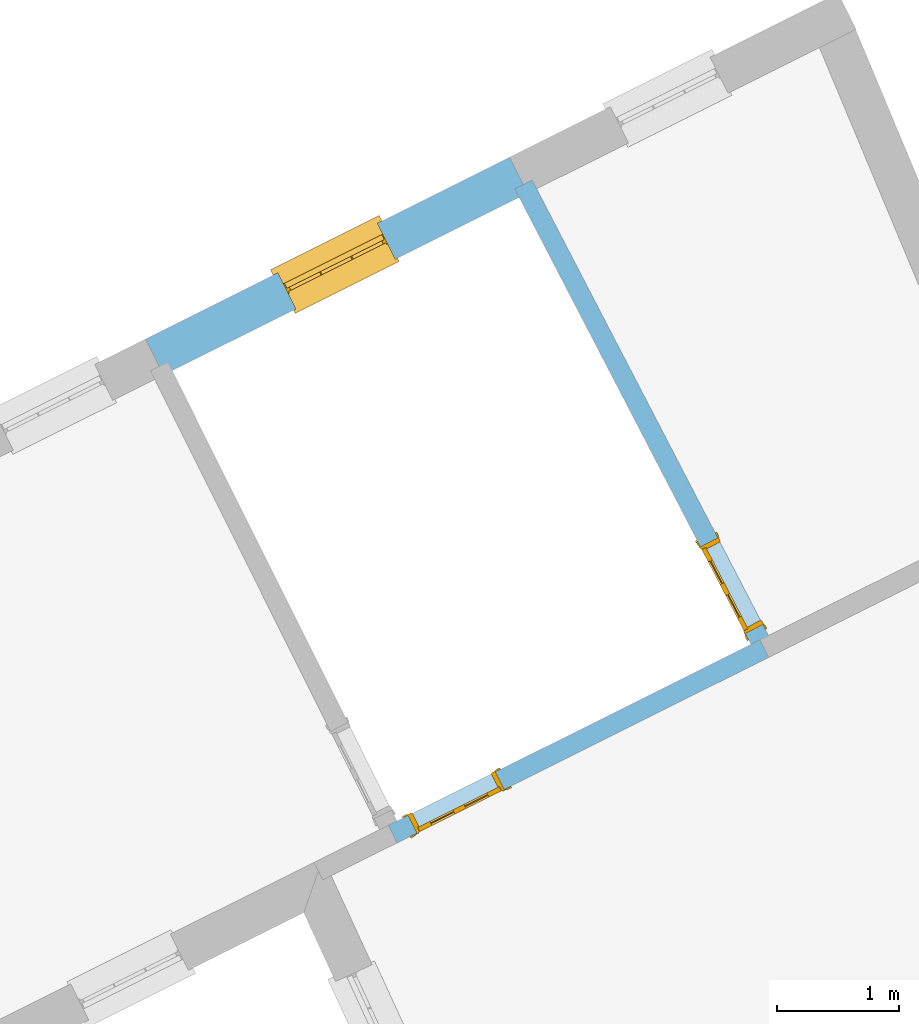
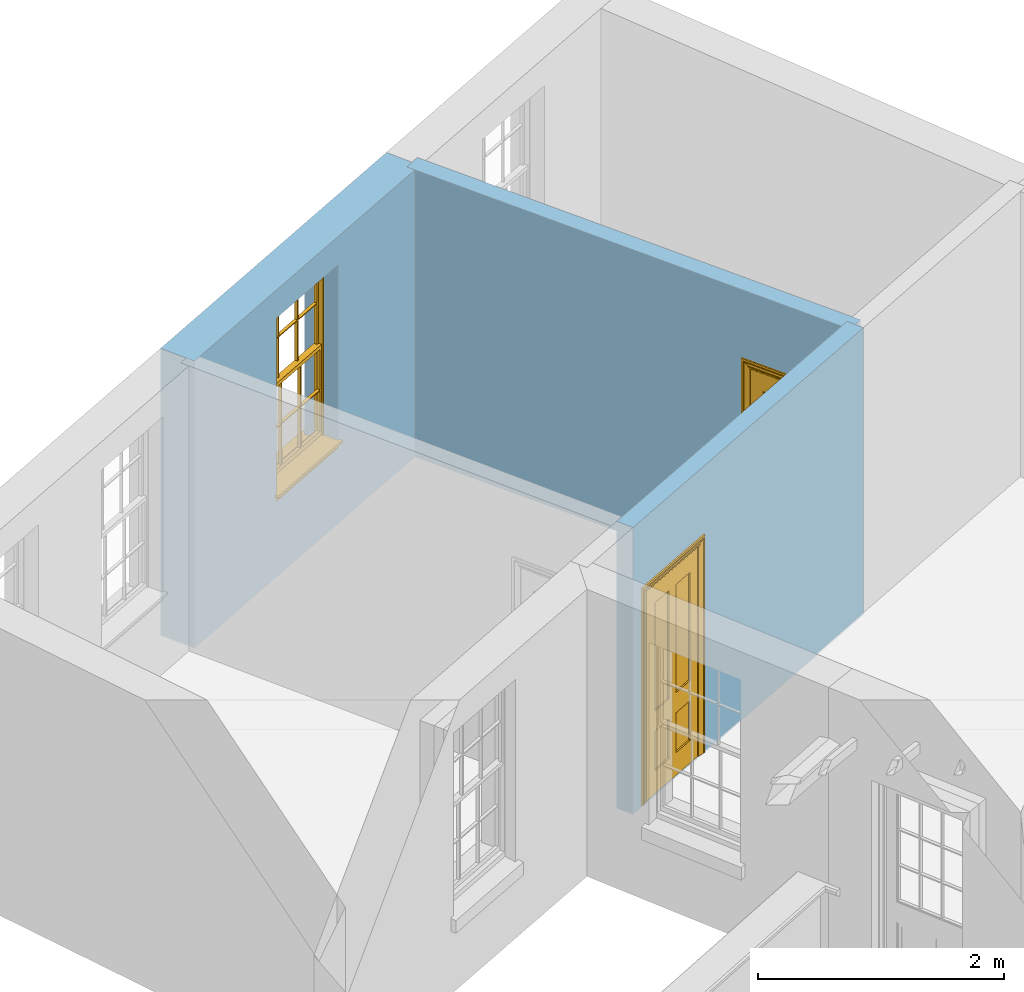
# One storey, part 6 of 9: 2 doors, 1 window, 3 openings, plus 3 elements that do not belong to this part.
"""IFC2X3 building model written with IfcOpenShell, lengths in metres."""

from ifc_helpers import new_model, si_unit, frame, origin, place, context, subcontext, project, spatial, polyline, outline, extrude, faceted_brep, material, layer, layer_set, layer_usage, element, fill, save


model = new_model("IFC2X3")

# Units and contexts
model_context = context("Model", 3, world=origin())
body_context = subcontext(model_context, "Body", "Model", "MODEL_VIEW")
ifc_project = project(units=[si_unit("PLANEANGLEUNIT", "RADIAN"), si_unit("MASSUNIT", "GRAM", prefix="KILO"), si_unit("FORCEUNIT", "NEWTON", prefix="KILO"), si_unit("LENGTHUNIT", "METRE")], contexts=[model_context])

# Site, building, storey
site_placement = place(None, origin())
site = spatial("IfcSite", under=ifc_project, at=site_placement, CompositionType="ELEMENT")
building_placement = place(None, origin())
building = spatial("IfcBuilding", under=site, at=building_placement, Name="Building plot-8", CompositionType="ELEMENT")
storey_placement = place(None, frame((0.0, 0.0, 3.45)))
storey = spatial("IfcBuildingStorey", under=building, at=storey_placement, Name="Floor 1", CompositionType="ELEMENT", Elevation=3.45)

# Wall, opening, window
ifc_material_1 = material(Name="Masonry")
ifc_layer_1 = layer(ifc_material_1, 0.33, ventilated=False)
ifc_layer_set_1 = layer_set([ifc_layer_1], Name="My Wall")
ifc_layer_usage_1 = layer_usage(ifc_layer_set_1, "AXIS2", "NEGATIVE", 0.08)
wall_1_placement = place(storey_placement, origin())
wall_1 = element("IfcWallStandardCase", 1, at=wall_1_placement, inside=storey, material=ifc_layer_usage_1, Name="exterior", context=body_context, shape_type="SweptSolid", body=[
    extrude(outline(polyline([(25.5117707560258, 18.5944455583952), (25.3643689149095, 18.889695786567), (22.3860129541837, 17.4027700868685), (22.5334147953, 17.1075198586967), (25.5117707560258, 18.5944455583952)])), origin(), (0.0, 0.0, 1.0), 2.85),
])
opening_1_placement = place(storey_placement, frame((0.0, 0.0, 0.75)))
opening_1 = element("IfcOpeningElement", 2, at=opening_1_placement, cuts=wall_1, Name="Opening", ObjectType="Opening", context=body_context, shape_type="SweptSolid", body=[
    extrude(outline(polyline([(24.2822783703593, 18.3494688085599), (23.4681034987339, 17.9429970648756), (23.6155053398501, 17.6477468367038), (24.4296802114756, 18.054218580388), (24.2822783703593, 18.3494688085599)])), origin(), (0.0, 0.0, 1.0), 1.82),
])
window_placement = place(storey_placement, frame((24.393946431811, 18.1257943932782, 0.75), z_axis=(0.0, 0.0, 1.0), x_axis=(-0.814174871625433, -0.406471743684246, 0.0)))
window = element("IfcWindow", 3, at=window_placement, inside=storey, Name="circulation outside window", OverallHeight=1.82, OverallWidth=0.91, context=body_context, shape_type="Brep", held_by="IfcProductRepresentation", body=[
    faceted_brep([(0.033125, -0.105, 0.975209), (0.01, -0.105, 0.975209), (0.033125, -0.105, 1.376042), (0.876875, -0.105, 0.975209), (0.876875, -0.105, 1.376042), (0.9, -0.105, 0.975209), (0.876875, -0.105, 1.386042), (0.876875, -0.105, 1.786875), (0.9, -0.105, 1.81), (0.033125, -0.105, 1.786875), (0.033125, -0.105, 1.386042), (0.01, -0.105, 1.81), (0.876875, -0.135, 1.376042), (0.876875, -0.135, 0.975209), (0.9, -0.135, 0.937083), (0.033125, -0.135, 1.786875), (0.01, -0.135, 1.81), (0.033125, -0.135, 1.386042), (0.01, -0.135, 0.937083), (0.033125, -0.135, 0.975209), (0.033125, -0.135, 1.376042), (0.876875, -0.135, 1.786875), (0.876875, -0.135, 1.386042), (0.9, -0.135, 1.81), (0.033125, -0.105, 0.937083), (0.01, -0.105, 0.937083), (0.033125, -0.105, 0.53625), (0.876875, -0.105, 0.937083), (0.876875, -0.105, 0.53625), (0.9, -0.105, 0.937083), (0.876875, -0.105, 0.52625), (0.876875, -0.105, 0.125417), (0.9, -0.105, 0.077167), (0.033125, -0.105, 0.125417), (0.033125, -0.105, 0.52625), (0.01, -0.105, 0.077167), (-0.0425, -0.25, 0.01), (-0.0425, -0.3, 0.001667), (0.0, -0.25, 0.01), (0.9525, -0.25, 0.01), (0.91, -0.25, 0.01), (0.9525, -0.3, 0.001667), (-0.02, 0.08, 0.077167), (0.0, 0.08, 0.077167), (-0.02, 0.11, 0.077167), (0.0, -0.06, 0.077167), (0.01, -0.06, 0.077167), (0.91, -0.06, 0.077167), (0.91, 0.08, 0.077167), (0.9, -0.06, 0.077167), (0.93, 0.08, 0.077167), (0.93, 0.11, 0.077167), (0.01, -0.075, 0.975209), (0.9, -0.075, 0.975209), (0.876875, -0.075, 0.125417), (0.876875, -0.075, 0.52625), (0.9, -0.075, 0.077167), (0.876875, -0.075, 0.53625), (0.876875, -0.075, 0.937083), (0.033125, -0.075, 0.125417), (0.01, -0.075, 0.077167), (0.033125, -0.075, 0.52625), (0.033125, -0.075, 0.937083), (0.033125, -0.075, 0.53625), (-0.02, 0.08, 0.052167), (-0.02, 0.11, 0.052167), (0.93, 0.11, 0.052167), (0.93, 0.08, 0.052167), (0.91, 0.08, 0.052167), (0.0, 0.08, 0.052167), (0.91, -0.15, 0.026667), (0.0, -0.15, 0.026667), (-0.0425, -0.3, -0.123333), (0.9525, -0.3, -0.123333), (-0.0425, -0.25, -0.123333), (0.9525, -0.25, -0.123333), (0.01, -0.06, 1.81), (0.9, -0.06, 1.81), (0.0, -0.06, 1.82), (0.91, -0.06, 1.82), (0.01, -0.15, 0.077167), (0.9, -0.15, 0.077167), (0.592292, -0.105, 0.125417), (0.592292, -0.075, 0.125417), (0.317708, -0.075, 0.125417), (0.317708, -0.105, 0.125417), (0.592292, -0.105, 0.53625), (0.317708, -0.105, 0.53625), (0.317708, -0.105, 0.52625), (0.592292, -0.105, 0.52625), (0.592292, -0.075, 0.53625), (0.317708, -0.075, 0.53625), (0.592292, -0.135, 1.386042), (0.592292, -0.105, 1.386042), (0.317708, -0.105, 1.386042), (0.317708, -0.135, 1.386042), (0.317708, -0.135, 1.376042), (0.592292, -0.135, 1.376042), (0.317708, -0.105, 1.376042), (0.592292, -0.105, 1.376042), (0.602292, -0.135, 1.376042), (0.592292, -0.135, 0.975209), (0.602292, -0.135, 0.975209), (0.602292, -0.105, 0.975209), (0.592292, -0.105, 0.975209), (0.602292, -0.105, 1.376042), (0.602292, -0.075, 0.53625), (0.602292, -0.105, 0.53625), (0.317708, -0.075, 0.52625), (0.307708, -0.075, 0.125417), (0.307708, -0.075, 0.52625), (0.602292, -0.075, 0.52625), (0.602292, -0.075, 0.125417), (0.592292, -0.075, 0.52625), (0.307708, -0.075, 0.53625), (0.317708, -0.075, 0.937083), (0.307708, -0.075, 0.937083), (0.602292, -0.075, 0.937083), (0.592292, -0.075, 0.937083), (0.307708, -0.105, 0.52625), (0.307708, -0.105, 0.125417), (0.307708, -0.105, 0.53625), (0.307708, -0.105, 0.937083), (0.592292, -0.105, 0.937083), (0.317708, -0.105, 0.937083), (0.602292, -0.105, 0.937083), (0.602292, -0.105, 0.52625), (0.602292, -0.105, 0.125417), (0.307708, -0.135, 1.386042), (0.307708, -0.135, 1.376042), (0.307708, -0.135, 0.975209), (0.317708, -0.135, 0.975209), (0.317708, -0.135, 1.786875), (0.307708, -0.135, 1.786875), (0.602292, -0.135, 1.786875), (0.592292, -0.135, 1.786875), (0.602292, -0.135, 1.386042), (0.602292, -0.105, 1.386042), (0.307708, -0.105, 1.386042), (0.307708, -0.105, 1.786875), (0.317708, -0.105, 1.786875), (0.592292, -0.105, 1.786875), (0.602292, -0.105, 1.786875), (0.307708, -0.105, 1.376042), (0.317708, -0.105, 0.975209), (0.307708, -0.105, 0.975209), (0.91, -0.15, 1.82), (0.9, -0.15, 1.81), (0.01, -0.15, 1.81), (0.0, -0.15, 1.82), (0.91, -0.25, 0.0), (0.0, -0.25, 0.0), (0.91, 0.08, 0.0), (0.0, 0.08, 0.0)], [[[0, 1, 2]], [[3, 4, 5]], [[6, 7, 8]], [[9, 10, 11]], [[12, 13, 14]], [[15, 16, 17]], [[18, 19, 20]], [[21, 22, 23]], [[24, 25, 26]], [[27, 28, 29]], [[30, 31, 32]], [[33, 34, 35]], [[14, 27, 29]], [[25, 24, 18]], [[36, 37, 38]], [[39, 40, 41]], [[42, 43, 44]], [[45, 46, 43]], [[47, 48, 49]], [[50, 51, 48]], [[1, 0, 52]], [[5, 53, 3]], [[54, 55, 56]], [[57, 58, 53]], [[59, 60, 61]], [[62, 63, 52]], [[48, 43, 46, 49]], [[51, 44, 43, 48]], [[64, 42, 44, 65]], [[65, 44, 51, 66]], [[66, 51, 50, 67]], [[65, 66, 68, 69]], [[60, 56, 49, 46]], [[70, 71, 38, 40]], [[37, 41, 40, 38]], [[37, 72, 73, 41]], [[74, 75, 73, 72]], [[8, 11, 76, 77]], [[76, 78, 79, 77]], [[32, 35, 80, 81]], [[81, 80, 71, 70]], [[82, 83, 84, 85]], [[86, 87, 88, 89]], [[86, 90, 91, 87]], [[92, 93, 94, 95]], [[92, 95, 96, 97]], [[96, 98, 99, 97]], [[100, 97, 101, 102]], [[103, 104, 99, 105]], [[97, 99, 104, 101]], [[102, 103, 105, 100]], [[28, 57, 106, 107]], [[108, 84, 109, 110]], [[111, 112, 83, 113]], [[114, 110, 61, 63]], [[90, 113, 108, 91]], [[115, 91, 114, 116]], [[117, 106, 90, 118]], [[111, 106, 57, 55]], [[119, 110, 109, 120]], [[34, 61, 110, 119]], [[89, 113, 83, 82]], [[88, 108, 113, 89]], [[85, 84, 108, 88]], [[121, 114, 63, 26]], [[122, 116, 114, 121]], [[123, 118, 90, 86]], [[87, 91, 115, 124]], [[107, 106, 117, 125]], [[126, 111, 55, 30]], [[127, 112, 111, 126]], [[126, 30, 28, 107]], [[88, 119, 120, 85]], [[126, 89, 82, 127]], [[125, 123, 86, 107]], [[121, 26, 34, 119]], [[124, 122, 121, 87]], [[128, 17, 20, 129]], [[96, 129, 130, 131]], [[132, 133, 128, 95]], [[134, 135, 92, 136]], [[100, 12, 22, 136]], [[137, 6, 4, 105]], [[94, 138, 139, 140]], [[137, 93, 141, 142]], [[99, 98, 94, 93]], [[143, 2, 10, 138]], [[144, 145, 143, 98]], [[129, 143, 145, 130]], [[20, 2, 143, 129]], [[131, 144, 98, 96]], [[128, 138, 10, 17]], [[133, 139, 138, 128]], [[135, 141, 93, 92]], [[95, 94, 140, 132]], [[22, 6, 137, 136]], [[136, 137, 142, 134]], [[100, 105, 4, 12]], [[107, 86, 89, 126]], [[106, 111, 113, 90]], [[91, 108, 110, 114]], [[87, 121, 119, 88]], [[97, 100, 136, 92]], [[129, 96, 95, 128]], [[98, 143, 138, 94]], [[105, 99, 93, 137]], [[131, 101, 104, 144]], [[124, 115, 118, 123]], [[132, 140, 141, 135]], [[120, 109, 59, 33]], [[15, 9, 139, 133]], [[134, 142, 7, 21]], [[31, 54, 112, 127]], [[36, 74, 72, 37]], [[39, 41, 73, 75]], [[18, 14, 101, 131]], [[23, 16, 132, 135]], [[83, 56, 60, 84]], [[52, 53, 118, 115]], [[53, 52, 144, 104]], [[11, 8, 141, 140]], [[14, 18, 124, 123]], [[2, 1, 11, 10]], [[8, 5, 4, 6]], [[57, 53, 56, 55]], [[60, 52, 63, 61]], [[26, 25, 35, 34]], [[32, 29, 28, 30]], [[14, 23, 22, 12]], [[18, 20, 17, 16]], [[19, 0, 2, 20]], [[17, 10, 9, 15]], [[12, 4, 3, 13]], [[21, 7, 6, 22]], [[27, 58, 57, 28]], [[30, 55, 54, 31]], [[33, 59, 61, 34]], [[26, 63, 62, 24]], [[5, 8, 77, 53]], [[76, 11, 1, 52]], [[46, 45, 78, 76]], [[49, 77, 79, 47]], [[70, 146, 147, 81]], [[71, 80, 148, 149]], [[19, 130, 145, 0]], [[102, 13, 3, 103]], [[116, 122, 24, 62]], [[29, 32, 81, 14]], [[80, 35, 25, 18]], [[60, 46, 76, 52]], [[77, 49, 56, 53]], [[23, 14, 81, 147]], [[16, 148, 80, 18]], [[35, 85, 120]], [[120, 33, 35]], [[127, 82, 32]], [[32, 31, 127]], [[32, 82, 85, 35]], [[102, 101, 14]], [[14, 13, 102]], [[18, 131, 130]], [[130, 19, 18]], [[134, 21, 23]], [[23, 135, 134]], [[16, 15, 133]], [[133, 132, 16]], [[11, 140, 139]], [[139, 9, 11]], [[142, 141, 8]], [[8, 7, 142]], [[23, 147, 148, 16]], [[146, 149, 148, 147]], [[52, 115, 116]], [[116, 62, 52]], [[118, 53, 117]], [[58, 117, 53]], [[27, 125, 117, 58]], [[56, 83, 112]], [[112, 54, 56]], [[109, 84, 60]], [[60, 59, 109]], [[125, 27, 14]], [[14, 123, 125]], [[122, 124, 18]], [[18, 24, 122]], [[145, 144, 52]], [[52, 0, 145]], [[103, 3, 53]], [[53, 104, 103]], [[79, 78, 149, 146]], [[78, 45, 71, 149]], [[146, 70, 47, 79]], [[150, 75, 74, 151]], [[68, 66, 67]], [[48, 68, 67, 50]], [[69, 64, 65]], [[42, 64, 69, 43]], [[69, 68, 152, 153]], [[70, 68, 48, 47]], [[150, 152, 68, 70]], [[43, 69, 71, 45]], [[69, 153, 151, 71]], [[152, 150, 151, 153]], [[38, 151, 74, 36]], [[71, 151, 38]], [[39, 75, 150, 40]], [[40, 150, 70]]]),
])
fill(opening_1, window)

# Wall, opening, door
ifc_material_2 = material(Name="Masonry")
ifc_layer_2 = layer(ifc_material_2, 0.16, ventilated=False)
ifc_layer_set_2 = layer_set([ifc_layer_2], Name="My Wall")
ifc_layer_usage_2 = layer_usage(ifc_layer_set_2, "AXIS2", "NEGATIVE", 0.08)
wall_2_placement = place(storey_placement, origin())
wall_2 = element("IfcWallStandardCase", 4, at=wall_2_placement, inside=storey, material=ifc_layer_usage_2, Name="interior", context=body_context, shape_type="SweptSolid", body=[
    extrude(outline(polyline([(27.4817132172852, 14.7989349376481), (27.4102456579562, 14.9420865634283), (24.3718074749693, 13.4251651877418), (24.4432750342983, 13.2820135619616), (27.4817132172852, 14.7989349376481)])), origin(), (0.0, 0.0, 1.0), 2.85),
])
opening_2_placement = place(storey_placement, frame((0.0, 0.0, 0.02)))
opening_2 = element("IfcOpeningElement", 5, at=opening_2_placement, cuts=wall_2, Name="Opening", ObjectType="Opening", context=body_context, shape_type="SweptSolid", body=[
    extrude(outline(polyline([(25.2486111828736, 13.8629039886326), (24.5328530539721, 13.5055661919871), (24.6043206133012, 13.3624145662068), (25.3200787422027, 13.7197523628523), (25.2486111828736, 13.8629039886326)])), origin(), (0.0, 0.0, 1.0), 2.1),
])
door_1_placement = place(storey_placement, frame((25.2843449625381, 13.7913281757424, 0.02), z_axis=(0.0, 0.0, 1.0), x_axis=(-0.715758128901484, -0.35733779664548, 0.0)))
door_1 = element("IfcDoor", 6, at=door_1_placement, inside=storey, Name="living inside door", OverallHeight=2.1, OverallWidth=0.8, context=body_context, shape_type="Brep", held_by="IfcProductRepresentation", body=[
    faceted_brep([(0.773, 0.08, 1.895), (0.66, 0.08, 1.895), (0.66, 0.08, 2.073), (0.773, 0.08, 2.073), (0.773, 0.08, 0.82), (0.66, 0.08, 0.82), (0.45, 0.08, 1.895), (0.45, 0.08, 2.073), (0.773, 0.08, 0.62), (0.66, 0.08, 0.62), (0.66, 0.065, 0.82), (0.66, 0.065, 1.895), (0.45, 0.065, 1.895), (0.35, 0.08, 1.895), (0.35, 0.08, 2.073), (0.773, 0.08, 0.225), (0.66, 0.08, 0.225), (0.45, 0.08, 0.62), (0.45, 0.08, 0.82), (0.45, 0.065, 0.82), (0.35, 0.08, 0.82), (0.14, 0.08, 2.073), (0.14, 0.08, 1.895), (0.773, 0.08, 0.0), (0.66, 0.08, 0.0), (0.66, 0.065, 0.225), (0.66, 0.065, 0.62), (0.45, 0.065, 0.62), (0.35, 0.08, 0.62), (0.35, 0.065, 0.82), (0.35, 0.065, 1.895), (0.14, 0.065, 1.895), (0.027, 0.08, 2.073), (0.027, 0.08, 1.895), (0.773, 0.042, 0.0), (0.66, 0.042, 0.0), (0.45, 0.08, 0.0), (0.45, 0.08, 0.225), (0.45, 0.065, 0.225), (0.35, 0.08, 0.225), (0.14, 0.08, 0.82), (0.14, 0.08, 0.62), (0.14, 0.065, 0.82), (0.027, 0.08, 0.82), (0.773, 0.042, 0.225), (0.66, 0.042, 0.225), (0.45, 0.042, 0.0), (0.35, 0.08, 0.0), (0.35, 0.065, 0.225), (0.35, 0.065, 0.62), (0.14, 0.065, 0.62), (0.027, 0.08, 0.62), (0.773, 0.042, 0.62), (0.66, 0.042, 0.62), (0.45, 0.042, 0.225), (0.35, 0.042, 0.0), (0.14, 0.08, 0.225), (0.14, 0.08, 0.0), (0.14, 0.065, 0.225), (0.027, 0.08, 0.225), (0.773, 0.042, 0.82), (0.66, 0.042, 0.82), (0.66, 0.057, 0.62), (0.66, 0.057, 0.225), (0.45, 0.057, 0.225), (0.35, 0.042, 0.225), (0.14, 0.042, 0.0), (0.027, 0.08, 0.0), (0.773, 0.042, 1.895), (0.66, 0.042, 1.895), (0.45, 0.042, 0.62), (0.45, 0.042, 0.82), (0.45, 0.057, 0.62), (0.35, 0.042, 0.62), (0.14, 0.042, 0.225), (0.027, 0.042, 0.0), (0.773, 0.042, 2.073), (0.66, 0.042, 2.073), (0.66, 0.057, 1.895), (0.66, 0.057, 0.82), (0.45, 0.057, 0.82), (0.35, 0.042, 0.82), (0.35, 0.057, 0.62), (0.35, 0.057, 0.225), (0.14, 0.057, 0.225), (0.027, 0.042, 0.225), (0.45, 0.042, 1.895), (0.45, 0.042, 2.073), (0.45, 0.057, 1.895), (0.35, 0.042, 1.895), (0.14, 0.042, 0.82), (0.14, 0.042, 0.62), (0.14, 0.057, 0.62), (0.027, 0.042, 0.62), (0.35, 0.042, 2.073), (0.35, 0.057, 1.895), (0.35, 0.057, 0.82), (0.14, 0.057, 0.82), (0.027, 0.042, 0.82), (0.14, 0.042, 2.073), (0.14, 0.042, 1.895), (0.14, 0.057, 1.895), (0.027, 0.042, 1.895), (0.027, 0.042, 2.073), (0.02, 0.085, 0.0), (0.005, 0.09, 0.0), (0.005, 0.09, 2.095), (0.02, 0.085, 2.08), (0.02, 0.08, 0.0), (0.0, 0.085, 0.0), (0.0, 0.085, 2.1), (0.795, 0.09, 2.095), (0.78, 0.085, 2.08), (0.02, 0.08, 2.08), (0.0, 0.08, 0.0), (-0.032, 0.095, 0.0), (-0.032, 0.095, 2.132), (0.8, 0.085, 2.1), (0.795, 0.09, 0.0), (0.78, 0.085, 0.0), (0.78, 0.08, 2.08), (0.04, 0.04, 0.0), (0.025, 0.04, 0.0), (0.025, 0.04, 2.075), (0.04, 0.04, 2.06), (-0.04, 0.09, 0.0), (-0.04, 0.09, 2.14), (0.832, 0.095, 2.132), (0.8, 0.085, 0.0), (0.78, 0.08, 0.0), (0.8, 0.08, 0.0), (0.86, 0.08, 0.0), (0.86, 0.08, 2.16), (0.8, 0.08, 2.1), (-0.06, 0.08, 2.16), (0.0, 0.08, 2.1), (-0.06, 0.08, 0.0), (-0.04, 0.095, 0.0), (-0.04, 0.095, 2.14), (0.84, 0.09, 2.14), (0.832, 0.095, 0.0), (0.84, 0.09, 0.0), (0.86, 0.095, 0.0), (0.86, 0.095, 2.16), (-0.06, 0.095, 2.16), (-0.06, 0.095, 0.0), (0.84, 0.095, 0.0), (0.84, 0.095, 2.14), (-0.025, -0.095, 0.0), (-0.025, -0.09, 0.0), (-0.025, -0.09, 2.125), (-0.025, -0.095, 2.125), (-0.017, -0.095, 0.0), (-0.017, -0.095, 2.117), (0.825, -0.09, 2.125), (0.825, -0.095, 2.125), (0.825, -0.095, 0.0), (0.845, -0.095, 0.0), (-0.045, -0.095, 2.145), (-0.045, -0.095, 0.0), (0.845, -0.095, 2.145), (0.015, -0.085, 0.0), (0.015, -0.085, 2.085), (0.817, -0.095, 2.117), (0.825, -0.09, 0.0), (0.845, -0.08, 0.0), (0.845, -0.08, 2.145), (-0.045, -0.08, 2.145), (-0.045, -0.08, 0.0), (0.02, -0.09, 0.0), (0.02, -0.09, 2.08), (0.785, -0.085, 2.085), (0.817, -0.095, 0.0), (0.8, -0.08, 0.0), (0.8, -0.08, 2.1), (0.0, -0.08, 2.1), (0.0, -0.08, 0.0), (0.035, -0.085, 0.0), (0.035, -0.085, 2.065), (0.78, -0.09, 2.08), (0.785, -0.085, 0.0), (0.775, 0.04, 2.075), (0.76, 0.04, 2.06), (0.035, -0.08, 2.065), (0.035, -0.08, 0.0), (0.765, -0.085, 2.065), (0.78, -0.09, 0.0), (0.765, -0.08, 0.0), (0.765, -0.08, 2.065), (0.765, -0.085, 0.0), (0.04, -0.08, 2.06), (0.04, -0.08, 0.0), (0.76, -0.08, 2.06), (0.76, -0.08, 0.0), (0.76, 0.04, 0.0), (0.775, 0.04, 0.0), (0.025, 0.08, 0.0), (0.025, 0.08, 2.075), (0.775, 0.08, 0.0), (0.775, 0.08, 2.075)], [[[0, 1, 2, 3]], [[1, 0, 4, 5]], [[1, 6, 7, 2]], [[8, 9, 5, 4]], [[1, 5, 10, 11]], [[6, 1, 11, 12]], [[6, 13, 14, 7]], [[15, 16, 9, 8]], [[9, 17, 18, 5]], [[5, 18, 19, 10]], [[10, 19, 12, 11]], [[18, 6, 12, 19]], [[18, 20, 13, 6]], [[21, 14, 13, 22]], [[23, 24, 16, 15]], [[9, 16, 25, 26]], [[17, 9, 26, 27]], [[17, 28, 20, 18]], [[13, 20, 29, 30]], [[22, 13, 30, 31]], [[32, 21, 22, 33]], [[34, 35, 24, 23]], [[24, 36, 37, 16]], [[16, 37, 38, 25]], [[25, 38, 27, 26]], [[37, 17, 27, 38]], [[37, 39, 28, 17]], [[40, 20, 28, 41]], [[20, 40, 42, 29]], [[31, 30, 29, 42]], [[40, 22, 31, 42]], [[33, 22, 40, 43]], [[35, 34, 44, 45]], [[35, 46, 36, 24]], [[36, 47, 39, 37]], [[28, 39, 48, 49]], [[41, 28, 49, 50]], [[43, 40, 41, 51]], [[45, 44, 52, 53]], [[46, 35, 45, 54]], [[46, 55, 47, 36]], [[56, 39, 47, 57]], [[39, 56, 58, 48]], [[50, 49, 48, 58]], [[56, 41, 50, 58]], [[51, 41, 56, 59]], [[53, 52, 60, 61]], [[45, 53, 62, 63]], [[54, 45, 63, 64]], [[55, 46, 54, 65]], [[55, 66, 57, 47]], [[59, 56, 57, 67]], [[61, 60, 68, 69]], [[70, 53, 61, 71]], [[53, 70, 72, 62]], [[72, 64, 63, 62]], [[70, 54, 64, 72]], [[65, 54, 70, 73]], [[65, 74, 66, 55]], [[67, 57, 66, 75]], [[69, 68, 76, 77]], [[61, 69, 78, 79]], [[71, 61, 79, 80]], [[73, 70, 71, 81]], [[65, 73, 82, 83]], [[74, 65, 83, 84]], [[74, 85, 75, 66]], [[86, 69, 77, 87]], [[69, 86, 88, 78]], [[88, 80, 79, 78]], [[86, 71, 80, 88]], [[81, 71, 86, 89]], [[73, 81, 90, 91]], [[73, 91, 92, 82]], [[83, 82, 92, 84]], [[91, 74, 84, 92]], [[91, 93, 85, 74]], [[89, 86, 87, 94]], [[81, 89, 95, 96]], [[90, 81, 96, 97]], [[90, 98, 93, 91]], [[94, 99, 100, 89]], [[89, 100, 101, 95]], [[101, 97, 96, 95]], [[100, 90, 97, 101]], [[100, 102, 98, 90]], [[99, 103, 102, 100]], [[32, 103, 99, 21]], [[102, 103, 32, 33]], [[98, 102, 33, 43]], [[21, 99, 94, 14]], [[94, 87, 7, 14]], [[7, 87, 77, 2]], [[76, 3, 2, 77]], [[43, 51, 93, 98]], [[51, 59, 85, 93]], [[67, 75, 85, 59]], [[34, 23, 15, 44]], [[44, 15, 8, 52]], [[52, 8, 4, 60]], [[0, 68, 60, 4]], [[0, 3, 76, 68]], [[104, 105, 106, 107]], [[104, 108, 109, 105]], [[105, 109, 110, 106]], [[107, 106, 111, 112]], [[107, 113, 108, 104]], [[114, 109, 108]], [[109, 115, 116, 110]], [[106, 110, 117, 111]], [[112, 111, 118, 119]], [[113, 107, 112, 120]], [[121, 122, 123, 124]], [[115, 109, 114, 125]], [[115, 125, 126, 116]], [[110, 116, 127, 117]], [[111, 117, 128, 118]], [[118, 128, 129, 119]], [[120, 112, 119, 129]], [[130, 129, 128]], [[130, 131, 132, 133]], [[133, 132, 134, 135]], [[135, 134, 136, 114]], [[136, 125, 114]], [[125, 137, 138, 126]], [[116, 126, 139, 127]], [[117, 127, 140, 128]], [[141, 130, 128, 140]], [[131, 130, 141]], [[131, 142, 143, 132]], [[132, 143, 144, 134]], [[134, 144, 145, 136]], [[137, 125, 136, 145]], [[143, 142, 146]], [[143, 146, 147]], [[137, 145, 144]], [[143, 147, 138]], [[138, 137, 144]], [[143, 138, 144]], [[126, 138, 147, 139]], [[127, 139, 141, 140]], [[142, 131, 141, 146]], [[139, 147, 146, 141]], [[148, 149, 150, 151]], [[149, 152, 153, 150]], [[151, 150, 154, 155]], [[155, 156, 157]], [[158, 159, 148]], [[158, 148, 151]], [[155, 157, 160]], [[158, 151, 155]], [[155, 160, 158]], [[152, 161, 162, 153]], [[150, 153, 163, 154]], [[155, 154, 164, 156]], [[156, 164, 165, 157]], [[157, 165, 166, 160]], [[160, 166, 167, 158]], [[158, 167, 168, 159]], [[161, 169, 170, 162]], [[153, 162, 171, 163]], [[154, 163, 172, 164]], [[165, 164, 173]], [[165, 173, 174, 166]], [[166, 174, 175, 167]], [[167, 175, 176, 168]], [[169, 177, 178, 170]], [[162, 170, 179, 171]], [[163, 171, 180, 172]], [[172, 180, 173, 164]], [[124, 123, 181, 182]], [[183, 178, 177, 184]], [[170, 178, 185, 179]], [[171, 179, 186, 180]], [[187, 173, 180]], [[185, 188, 187, 189]], [[188, 185, 178, 183]], [[179, 185, 189, 186]], [[189, 187, 180, 186]], [[190, 183, 184, 191]], [[192, 188, 183, 190]], [[191, 184, 122, 121]], [[124, 190, 191, 121]], [[193, 187, 188, 192]], [[182, 192, 190, 124]], [[184, 176, 122]], [[194, 195, 187, 193]], [[192, 182, 194, 193]], [[161, 176, 184]], [[114, 108, 122, 176]], [[173, 187, 195]], [[152, 149, 176, 161]], [[169, 161, 184, 177]], [[196, 122, 108]], [[176, 175, 135, 114]], [[173, 195, 129, 130]], [[176, 149, 168]], [[123, 122, 196, 197]], [[196, 108, 113, 197]], [[175, 174, 133, 135]], [[198, 129, 195]], [[133, 174, 173, 130]], [[159, 168, 149, 148]], [[181, 123, 197, 199]], [[197, 113, 120, 199]], [[199, 120, 129, 198]], [[195, 181, 199, 198]], [[195, 194, 182, 181]]]),
])
fill(opening_2, door_1)

wall_3_placement = place(storey_placement, origin())
wall_3 = element("IfcWallStandardCase", 7, at=wall_3_placement, inside=storey, material=ifc_layer_usage_2, Name="interior", context=body_context, shape_type="SweptSolid", body=[
    extrude(outline(polyline([(27.374973605375, 14.8336573682362), (27.5169852698664, 14.9073641328402), (25.5470428086069, 18.7028747535873), (25.4050311441155, 18.6291679889833), (27.374973605375, 14.8336573682362)])), origin(), (0.0, 0.0, 1.0), 2.85),
])
opening_3_placement = place(storey_placement, frame((0.0, 0.0, 0.02)))
opening_3 = element("IfcOpeningElement", 8, at=opening_3_placement, cuts=wall_3, Name="Opening", ObjectType="Opening", context=body_context, shape_type="SweptSolid", body=[
    extrude(outline(polyline([(27.4340651596868, 15.067127255393), (27.0655313366665, 15.7771855778497), (26.9235196721751, 15.7034788132456), (27.2920534951955, 14.9934204907889), (27.4340651596868, 15.067127255393)])), origin(), (0.0, 0.0, 1.0), 2.1),
])
door_2_placement = place(storey_placement, frame((27.3630593274411, 15.030273873091, 0.02), z_axis=(0.0, 0.0, 1.0), x_axis=(-0.368533823020318, 0.710058322456703, 0.0)))
door_2 = element("IfcDoor", 9, at=door_2_placement, inside=storey, Name="bedroom inside door", OverallHeight=2.1, OverallWidth=0.8, context=body_context, shape_type="Brep", held_by="IfcProductRepresentation", body=[
    faceted_brep([(0.773, 0.08, 1.895), (0.66, 0.08, 1.895), (0.66, 0.08, 2.073), (0.773, 0.08, 2.073), (0.773, 0.08, 0.82), (0.66, 0.08, 0.82), (0.45, 0.08, 1.895), (0.45, 0.08, 2.073), (0.773, 0.08, 0.62), (0.66, 0.08, 0.62), (0.66, 0.065, 0.82), (0.66, 0.065, 1.895), (0.45, 0.065, 1.895), (0.35, 0.08, 1.895), (0.35, 0.08, 2.073), (0.773, 0.08, 0.225), (0.66, 0.08, 0.225), (0.45, 0.08, 0.62), (0.45, 0.08, 0.82), (0.45, 0.065, 0.82), (0.35, 0.08, 0.82), (0.14, 0.08, 2.073), (0.14, 0.08, 1.895), (0.773, 0.08, 0.0), (0.66, 0.08, 0.0), (0.66, 0.065, 0.225), (0.66, 0.065, 0.62), (0.45, 0.065, 0.62), (0.35, 0.08, 0.62), (0.35, 0.065, 0.82), (0.35, 0.065, 1.895), (0.14, 0.065, 1.895), (0.027, 0.08, 2.073), (0.027, 0.08, 1.895), (0.773, 0.042, 0.0), (0.66, 0.042, 0.0), (0.45, 0.08, 0.0), (0.45, 0.08, 0.225), (0.45, 0.065, 0.225), (0.35, 0.08, 0.225), (0.14, 0.08, 0.82), (0.14, 0.08, 0.62), (0.14, 0.065, 0.82), (0.027, 0.08, 0.82), (0.773, 0.042, 0.225), (0.66, 0.042, 0.225), (0.45, 0.042, 0.0), (0.35, 0.08, 0.0), (0.35, 0.065, 0.225), (0.35, 0.065, 0.62), (0.14, 0.065, 0.62), (0.027, 0.08, 0.62), (0.773, 0.042, 0.62), (0.66, 0.042, 0.62), (0.45, 0.042, 0.225), (0.35, 0.042, 0.0), (0.14, 0.08, 0.225), (0.14, 0.08, 0.0), (0.14, 0.065, 0.225), (0.027, 0.08, 0.225), (0.773, 0.042, 0.82), (0.66, 0.042, 0.82), (0.66, 0.057, 0.62), (0.66, 0.057, 0.225), (0.45, 0.057, 0.225), (0.35, 0.042, 0.225), (0.14, 0.042, 0.0), (0.027, 0.08, 0.0), (0.773, 0.042, 1.895), (0.66, 0.042, 1.895), (0.45, 0.042, 0.62), (0.45, 0.042, 0.82), (0.45, 0.057, 0.62), (0.35, 0.042, 0.62), (0.14, 0.042, 0.225), (0.027, 0.042, 0.0), (0.773, 0.042, 2.073), (0.66, 0.042, 2.073), (0.66, 0.057, 1.895), (0.66, 0.057, 0.82), (0.45, 0.057, 0.82), (0.35, 0.042, 0.82), (0.35, 0.057, 0.62), (0.35, 0.057, 0.225), (0.14, 0.057, 0.225), (0.027, 0.042, 0.225), (0.45, 0.042, 1.895), (0.45, 0.042, 2.073), (0.45, 0.057, 1.895), (0.35, 0.042, 1.895), (0.14, 0.042, 0.82), (0.14, 0.042, 0.62), (0.14, 0.057, 0.62), (0.027, 0.042, 0.62), (0.35, 0.042, 2.073), (0.35, 0.057, 1.895), (0.35, 0.057, 0.82), (0.14, 0.057, 0.82), (0.027, 0.042, 0.82), (0.14, 0.042, 2.073), (0.14, 0.042, 1.895), (0.14, 0.057, 1.895), (0.027, 0.042, 1.895), (0.027, 0.042, 2.073), (0.02, 0.085, 0.0), (0.005, 0.09, 0.0), (0.005, 0.09, 2.095), (0.02, 0.085, 2.08), (0.02, 0.08, 0.0), (0.0, 0.085, 0.0), (0.0, 0.085, 2.1), (0.795, 0.09, 2.095), (0.78, 0.085, 2.08), (0.02, 0.08, 2.08), (0.0, 0.08, 0.0), (-0.032, 0.095, 0.0), (-0.032, 0.095, 2.132), (0.8, 0.085, 2.1), (0.795, 0.09, 0.0), (0.78, 0.085, 0.0), (0.78, 0.08, 2.08), (0.04, 0.04, 0.0), (0.025, 0.04, 0.0), (0.025, 0.04, 2.075), (0.04, 0.04, 2.06), (-0.04, 0.09, 0.0), (-0.04, 0.09, 2.14), (0.832, 0.095, 2.132), (0.8, 0.085, 0.0), (0.78, 0.08, 0.0), (0.8, 0.08, 0.0), (0.86, 0.08, 0.0), (0.86, 0.08, 2.16), (0.8, 0.08, 2.1), (-0.06, 0.08, 2.16), (0.0, 0.08, 2.1), (-0.06, 0.08, 0.0), (-0.04, 0.095, 0.0), (-0.04, 0.095, 2.14), (0.84, 0.09, 2.14), (0.832, 0.095, 0.0), (0.84, 0.09, 0.0), (0.86, 0.095, 0.0), (0.86, 0.095, 2.16), (-0.06, 0.095, 2.16), (-0.06, 0.095, 0.0), (0.84, 0.095, 0.0), (0.84, 0.095, 2.14), (-0.025, -0.095, 0.0), (-0.025, -0.09, 0.0), (-0.025, -0.09, 2.125), (-0.025, -0.095, 2.125), (-0.017, -0.095, 0.0), (-0.017, -0.095, 2.117), (0.825, -0.09, 2.125), (0.825, -0.095, 2.125), (0.825, -0.095, 0.0), (0.845, -0.095, 0.0), (-0.045, -0.095, 2.145), (-0.045, -0.095, 0.0), (0.845, -0.095, 2.145), (0.015, -0.085, 0.0), (0.015, -0.085, 2.085), (0.817, -0.095, 2.117), (0.825, -0.09, 0.0), (0.845, -0.08, 0.0), (0.845, -0.08, 2.145), (-0.045, -0.08, 2.145), (-0.045, -0.08, 0.0), (0.02, -0.09, 0.0), (0.02, -0.09, 2.08), (0.785, -0.085, 2.085), (0.817, -0.095, 0.0), (0.8, -0.08, 0.0), (0.8, -0.08, 2.1), (0.0, -0.08, 2.1), (0.0, -0.08, 0.0), (0.035, -0.085, 0.0), (0.035, -0.085, 2.065), (0.78, -0.09, 2.08), (0.785, -0.085, 0.0), (0.775, 0.04, 2.075), (0.76, 0.04, 2.06), (0.035, -0.08, 2.065), (0.035, -0.08, 0.0), (0.765, -0.085, 2.065), (0.78, -0.09, 0.0), (0.765, -0.08, 0.0), (0.765, -0.08, 2.065), (0.765, -0.085, 0.0), (0.04, -0.08, 2.06), (0.04, -0.08, 0.0), (0.76, -0.08, 2.06), (0.76, -0.08, 0.0), (0.76, 0.04, 0.0), (0.775, 0.04, 0.0), (0.025, 0.08, 0.0), (0.025, 0.08, 2.075), (0.775, 0.08, 0.0), (0.775, 0.08, 2.075)], [[[0, 1, 2, 3]], [[1, 0, 4, 5]], [[1, 6, 7, 2]], [[8, 9, 5, 4]], [[1, 5, 10, 11]], [[6, 1, 11, 12]], [[6, 13, 14, 7]], [[15, 16, 9, 8]], [[9, 17, 18, 5]], [[5, 18, 19, 10]], [[10, 19, 12, 11]], [[18, 6, 12, 19]], [[18, 20, 13, 6]], [[21, 14, 13, 22]], [[23, 24, 16, 15]], [[9, 16, 25, 26]], [[17, 9, 26, 27]], [[17, 28, 20, 18]], [[13, 20, 29, 30]], [[22, 13, 30, 31]], [[32, 21, 22, 33]], [[34, 35, 24, 23]], [[24, 36, 37, 16]], [[16, 37, 38, 25]], [[25, 38, 27, 26]], [[37, 17, 27, 38]], [[37, 39, 28, 17]], [[40, 20, 28, 41]], [[20, 40, 42, 29]], [[31, 30, 29, 42]], [[40, 22, 31, 42]], [[33, 22, 40, 43]], [[35, 34, 44, 45]], [[35, 46, 36, 24]], [[36, 47, 39, 37]], [[28, 39, 48, 49]], [[41, 28, 49, 50]], [[43, 40, 41, 51]], [[45, 44, 52, 53]], [[46, 35, 45, 54]], [[46, 55, 47, 36]], [[56, 39, 47, 57]], [[39, 56, 58, 48]], [[50, 49, 48, 58]], [[56, 41, 50, 58]], [[51, 41, 56, 59]], [[53, 52, 60, 61]], [[45, 53, 62, 63]], [[54, 45, 63, 64]], [[55, 46, 54, 65]], [[55, 66, 57, 47]], [[59, 56, 57, 67]], [[61, 60, 68, 69]], [[70, 53, 61, 71]], [[53, 70, 72, 62]], [[72, 64, 63, 62]], [[70, 54, 64, 72]], [[65, 54, 70, 73]], [[65, 74, 66, 55]], [[67, 57, 66, 75]], [[69, 68, 76, 77]], [[61, 69, 78, 79]], [[71, 61, 79, 80]], [[73, 70, 71, 81]], [[65, 73, 82, 83]], [[74, 65, 83, 84]], [[74, 85, 75, 66]], [[86, 69, 77, 87]], [[69, 86, 88, 78]], [[88, 80, 79, 78]], [[86, 71, 80, 88]], [[81, 71, 86, 89]], [[73, 81, 90, 91]], [[73, 91, 92, 82]], [[83, 82, 92, 84]], [[91, 74, 84, 92]], [[91, 93, 85, 74]], [[89, 86, 87, 94]], [[81, 89, 95, 96]], [[90, 81, 96, 97]], [[90, 98, 93, 91]], [[94, 99, 100, 89]], [[89, 100, 101, 95]], [[101, 97, 96, 95]], [[100, 90, 97, 101]], [[100, 102, 98, 90]], [[99, 103, 102, 100]], [[32, 103, 99, 21]], [[102, 103, 32, 33]], [[98, 102, 33, 43]], [[21, 99, 94, 14]], [[94, 87, 7, 14]], [[7, 87, 77, 2]], [[76, 3, 2, 77]], [[43, 51, 93, 98]], [[51, 59, 85, 93]], [[67, 75, 85, 59]], [[34, 23, 15, 44]], [[44, 15, 8, 52]], [[52, 8, 4, 60]], [[0, 68, 60, 4]], [[0, 3, 76, 68]], [[104, 105, 106, 107]], [[104, 108, 109, 105]], [[105, 109, 110, 106]], [[107, 106, 111, 112]], [[107, 113, 108, 104]], [[114, 109, 108]], [[109, 115, 116, 110]], [[106, 110, 117, 111]], [[112, 111, 118, 119]], [[113, 107, 112, 120]], [[121, 122, 123, 124]], [[115, 109, 114, 125]], [[115, 125, 126, 116]], [[110, 116, 127, 117]], [[111, 117, 128, 118]], [[118, 128, 129, 119]], [[120, 112, 119, 129]], [[130, 129, 128]], [[130, 131, 132, 133]], [[133, 132, 134, 135]], [[135, 134, 136, 114]], [[136, 125, 114]], [[125, 137, 138, 126]], [[116, 126, 139, 127]], [[117, 127, 140, 128]], [[141, 130, 128, 140]], [[131, 130, 141]], [[131, 142, 143, 132]], [[132, 143, 144, 134]], [[134, 144, 145, 136]], [[137, 125, 136, 145]], [[143, 142, 146]], [[143, 146, 147]], [[137, 145, 144]], [[143, 147, 138]], [[138, 137, 144]], [[143, 138, 144]], [[126, 138, 147, 139]], [[127, 139, 141, 140]], [[142, 131, 141, 146]], [[139, 147, 146, 141]], [[148, 149, 150, 151]], [[149, 152, 153, 150]], [[151, 150, 154, 155]], [[155, 156, 157]], [[158, 159, 148]], [[158, 148, 151]], [[155, 157, 160]], [[158, 151, 155]], [[155, 160, 158]], [[152, 161, 162, 153]], [[150, 153, 163, 154]], [[155, 154, 164, 156]], [[156, 164, 165, 157]], [[157, 165, 166, 160]], [[160, 166, 167, 158]], [[158, 167, 168, 159]], [[161, 169, 170, 162]], [[153, 162, 171, 163]], [[154, 163, 172, 164]], [[165, 164, 173]], [[165, 173, 174, 166]], [[166, 174, 175, 167]], [[167, 175, 176, 168]], [[169, 177, 178, 170]], [[162, 170, 179, 171]], [[163, 171, 180, 172]], [[172, 180, 173, 164]], [[124, 123, 181, 182]], [[183, 178, 177, 184]], [[170, 178, 185, 179]], [[171, 179, 186, 180]], [[187, 173, 180]], [[185, 188, 187, 189]], [[188, 185, 178, 183]], [[179, 185, 189, 186]], [[189, 187, 180, 186]], [[190, 183, 184, 191]], [[192, 188, 183, 190]], [[191, 184, 122, 121]], [[124, 190, 191, 121]], [[193, 187, 188, 192]], [[182, 192, 190, 124]], [[184, 176, 122]], [[194, 195, 187, 193]], [[192, 182, 194, 193]], [[161, 176, 184]], [[114, 108, 122, 176]], [[173, 187, 195]], [[152, 149, 176, 161]], [[169, 161, 184, 177]], [[196, 122, 108]], [[176, 175, 135, 114]], [[173, 195, 129, 130]], [[176, 149, 168]], [[123, 122, 196, 197]], [[196, 108, 113, 197]], [[175, 174, 133, 135]], [[198, 129, 195]], [[133, 174, 173, 130]], [[159, 168, 149, 148]], [[181, 123, 197, 199]], [[197, 113, 120, 199]], [[199, 120, 129, 198]], [[195, 181, 199, 198]], [[195, 194, 182, 181]]]),
])
fill(opening_3, door_2)

save(model, "model.ifc")
